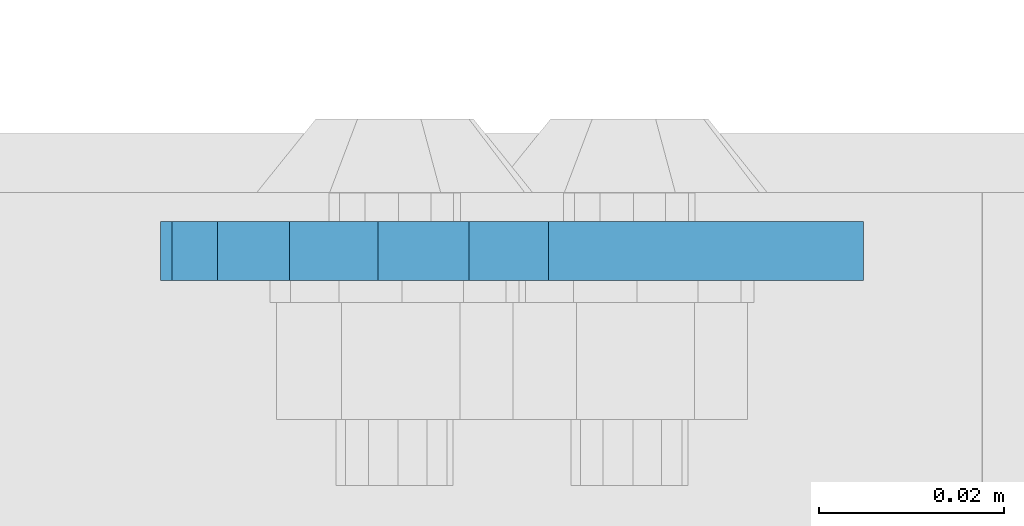
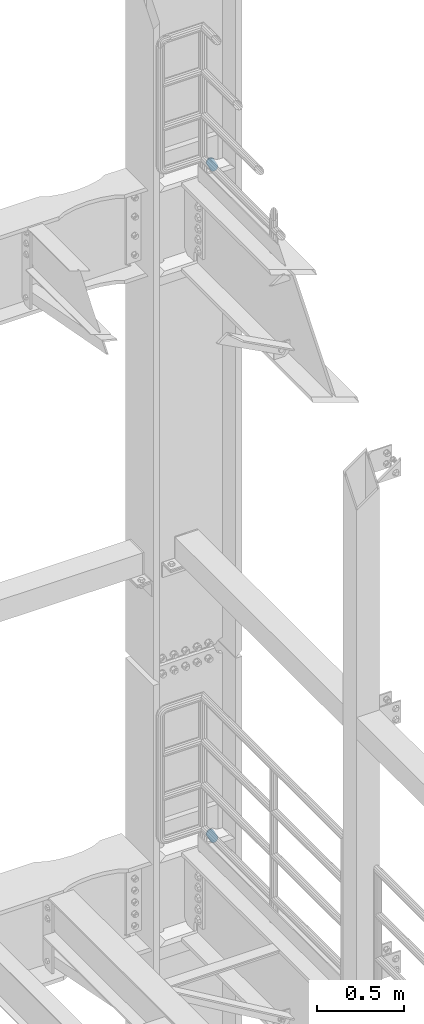
# One storey, part 1825 of 1876: 2 plates, 2 elements without a shape of their own.
"""IFC2X3 building model written with IfcOpenShell, lengths in millimetres."""

from ifc_helpers import new_model, si_unit, frame, origin_with_axes, place, context, subcontext, project, spatial, faceted_brep, material, type_object, element, aggregate, save


model = new_model("IFC2X3")

# Units and contexts
model_context = context("Model", 3, precision=1e-05, world=origin_with_axes())
body_context = subcontext(model_context, "Body", "Model", "MODEL_VIEW")
ifc_project = project(units=[si_unit("LENGTHUNIT", "METRE", prefix="MILLI"), si_unit("AREAUNIT", "SQUARE_METRE"), si_unit("VOLUMEUNIT", "CUBIC_METRE"), si_unit("MASSUNIT", "GRAM", prefix="KILO"), si_unit("TIMEUNIT", "SECOND"), si_unit("PLANEANGLEUNIT", "RADIAN"), si_unit("SOLIDANGLEUNIT", "STERADIAN"), si_unit("THERMODYNAMICTEMPERATUREUNIT", "DEGREE_CELSIUS"), si_unit("LUMINOUSINTENSITYUNIT", "LUMEN")], contexts=[model_context])

# Site, building, storey
site_placement = place(None, origin_with_axes())
site = spatial("IfcSite", under=ifc_project, at=site_placement, CompositionType="ELEMENT")
building_placement = place(site_placement, origin_with_axes())
building = spatial("IfcBuilding", under=site, at=building_placement, Name="Undefined", CompositionType="ELEMENT")
storey_placement = place(building_placement, origin_with_axes())
storey = spatial("IfcBuildingStorey", under=building, at=storey_placement, Name="Undefined", CompositionType="ELEMENT", Elevation=0.0)

# Assembly, plate
assembly_1_placement = place(storey_placement, origin_with_axes())
assembly_1 = element("IfcElementAssembly", 1, at=assembly_1_placement, inside=storey, Name="PLATE", AssemblyPlace="NOTDEFINED", PredefinedType="RIGID_FRAME")
ifc_material = material(Name="STEEL/A36")
plate_type = type_object("IfcPlateType", PredefinedType="NOTDEFINED")
plate_1_placement = place(assembly_1_placement, frame((7974.16265108452, 14008.1000023123, 17725.1776774809), z_axis=(-0.894427191199917, 1.49999996210681e-08, -0.447213595099955), x_axis=(0.447213595099955, -6.99999707257281e-09, -0.894427191199917)))
plate_1 = element("IfcPlate", 2, at=plate_1_placement, type_object=plate_type, material=ifc_material, Name="PLATE", context=body_context, shape_type="Brep", body=[
    faceted_brep([(-8.59611645864788e-07, -3.17499999999654, 25.3999987589127), (1.93345873884391, -3.17499999999382, 35.1201580589886), (1.93345873884391, 3.17500000000564, 35.1201580589886), (-8.59611645864788e-07, 3.17500000000382, 25.3999987589132), (7.43948648259902, -3.17499999999109, 43.3605112870105), (7.43948648259902, 3.17500000000928, 43.3605112870105), (15.6798395242777, -3.17499999998654, 48.8665393096448), (15.6798395242777, 3.17500000001382, 48.8665393096448), (25.3999987589095, -3.17499999998199, 50.7999992370592), (25.3999987589095, 3.17500000001837, 50.7999992370592), (82.196130752618, -3.17499999998381, 50.7999992370605), (82.196130752618, 3.17500000001655, 50.7999992370642), (91.9162897887145, -3.17499999997926, 48.8665393918873), (91.9162897887145, 3.1750000000211, 48.8665393918909), (100.156642725027, -3.17499999997472, 43.3605115909359), (100.156642725027, 3.17500000002565, 43.3605115909395), (105.662670525982, -3.17499999997108, 35.1201586546285), (105.662670525986, 3.17500000002929, 35.1201586546358), (107.596130371159, -3.17499999996744, 25.3999996185757), (107.596130371159, 3.17500000003292, 25.3999996185794), (105.662670525981, -3.17499999996471, 15.6798405824902), (105.662670525981, 3.17500000003565, 15.6798405824939), (100.156642725024, -3.17499999996471, 7.43948764618654), (100.156642725025, 3.17500000003565, 7.43948764619017), (91.9162897887127, -3.17499999996562, 1.93345984522784), (91.9162897887127, 3.17500000003474, 1.93345984523148), (82.196130752618, -3.17499999996835, 4.54747350886464e-11), (82.196130752618, 3.1750000000311, 4.91127138957381e-11), (25.399998758905, -3.17499999999018, -8.64019966684282e-12), (25.399998758905, 3.17500000001019, -8.64019966684282e-12), (15.679839921364, -3.17499999999382, 1.9334597629304), (15.679839921364, 3.17500000000655, 1.9334597629304), (7.43948709043525, -3.17499999999654, 7.43948734220839), (7.43948709043525, 3.17500000000382, 7.43948734220885), (1.93345923228208, -3.17499999999654, 15.6798399868012), (1.93345923228208, 3.17500000000291, 15.6798399868012)], [[[0, 1, 2, 3]], [[1, 4, 5, 2]], [[4, 6, 7, 5]], [[6, 8, 9, 7]], [[8, 10, 11, 9]], [[10, 12, 13, 11]], [[12, 14, 15, 13]], [[14, 16, 17, 15]], [[16, 18, 19, 17]], [[18, 20, 21, 19]], [[20, 22, 23, 21]], [[22, 24, 25, 23]], [[24, 26, 27, 25]], [[26, 28, 29, 27]], [[28, 30, 31, 29]], [[30, 32, 33, 31]], [[32, 34, 35, 33]], [[34, 0, 3, 35]], [[5, 7, 9, 11, 13, 15, 17, 19, 21, 23, 25, 27, 29, 31, 33, 35, 3, 2]], [[34, 32, 30, 28, 26, 24, 22, 20, 18, 16, 14, 12, 10, 8, 6, 4, 1, 0]]]),
])
aggregate(assembly_1, [plate_1])

assembly_2_placement = place(storey_placement, origin_with_axes())
assembly_2 = element("IfcElementAssembly", 3, at=assembly_2_placement, inside=storey, Name="PLATE", AssemblyPlace="NOTDEFINED", PredefinedType="RIGID_FRAME")
plate_2_placement = place(assembly_2_placement, frame((7974.16265108242, 14008.1000023123, 13038.8776774809), z_axis=(-0.894427191199917, 1.49999996210681e-08, -0.447213595099955), x_axis=(0.447213595099955, -6.99999707257281e-09, -0.894427191199917)))
plate_2 = element("IfcPlate", 4, at=plate_2_placement, type_object=plate_type, material=ifc_material, Name="PLATE", context=body_context, shape_type="Brep", body=[
    faceted_brep([(-8.59611645864788e-07, -3.17499999999654, 25.3999987589127), (1.93345873884391, -3.17499999999382, 35.1201580589886), (1.93345873884391, 3.17500000000564, 35.1201580589886), (-8.59611645864788e-07, 3.17500000000382, 25.3999987589132), (7.43948648259902, -3.17499999999109, 43.3605112870105), (7.43948648259902, 3.17500000000928, 43.3605112870105), (15.6798395242777, -3.17499999998654, 48.8665393096448), (15.6798395242777, 3.17500000001382, 48.8665393096448), (25.3999987589095, -3.17499999998199, 50.7999992370592), (25.3999987589095, 3.17500000001837, 50.7999992370592), (82.196130752618, -3.17499999998381, 50.7999992370605), (82.196130752618, 3.17500000001655, 50.7999992370642), (91.9162897887145, -3.17499999997926, 48.8665393918873), (91.9162897887145, 3.1750000000211, 48.8665393918909), (100.156642725027, -3.17499999997472, 43.3605115909359), (100.156642725027, 3.17500000002565, 43.3605115909395), (105.662670525982, -3.17499999997108, 35.1201586546285), (105.662670525986, 3.17500000002929, 35.1201586546358), (107.596130371159, -3.17499999996744, 25.3999996185757), (107.596130371159, 3.17500000003292, 25.3999996185794), (105.662670525981, -3.17499999996471, 15.6798405824902), (105.662670525981, 3.17500000003565, 15.6798405824939), (100.156642725024, -3.17499999996471, 7.43948764618654), (100.156642725025, 3.17500000003565, 7.43948764619017), (91.9162897887127, -3.17499999996562, 1.93345984522784), (91.9162897887127, 3.17500000003474, 1.93345984523148), (82.196130752618, -3.17499999996835, 4.54747350886464e-11), (82.196130752618, 3.1750000000311, 4.91127138957381e-11), (25.399998758905, -3.17499999999018, -8.64019966684282e-12), (25.399998758905, 3.17500000001019, -8.64019966684282e-12), (15.679839921364, -3.17499999999382, 1.9334597629304), (15.679839921364, 3.17500000000655, 1.9334597629304), (7.43948709043525, -3.17499999999654, 7.43948734220839), (7.43948709043525, 3.17500000000382, 7.43948734220885), (1.93345923228208, -3.17499999999654, 15.6798399868012), (1.93345923228208, 3.17500000000291, 15.6798399868012)], [[[0, 1, 2, 3]], [[1, 4, 5, 2]], [[4, 6, 7, 5]], [[6, 8, 9, 7]], [[8, 10, 11, 9]], [[10, 12, 13, 11]], [[12, 14, 15, 13]], [[14, 16, 17, 15]], [[16, 18, 19, 17]], [[18, 20, 21, 19]], [[20, 22, 23, 21]], [[22, 24, 25, 23]], [[24, 26, 27, 25]], [[26, 28, 29, 27]], [[28, 30, 31, 29]], [[30, 32, 33, 31]], [[32, 34, 35, 33]], [[34, 0, 3, 35]], [[5, 7, 9, 11, 13, 15, 17, 19, 21, 23, 25, 27, 29, 31, 33, 35, 3, 2]], [[34, 32, 30, 28, 26, 24, 22, 20, 18, 16, 14, 12, 10, 8, 6, 4, 1, 0]]]),
])
aggregate(assembly_2, [plate_2])

save(model, "model.ifc")
